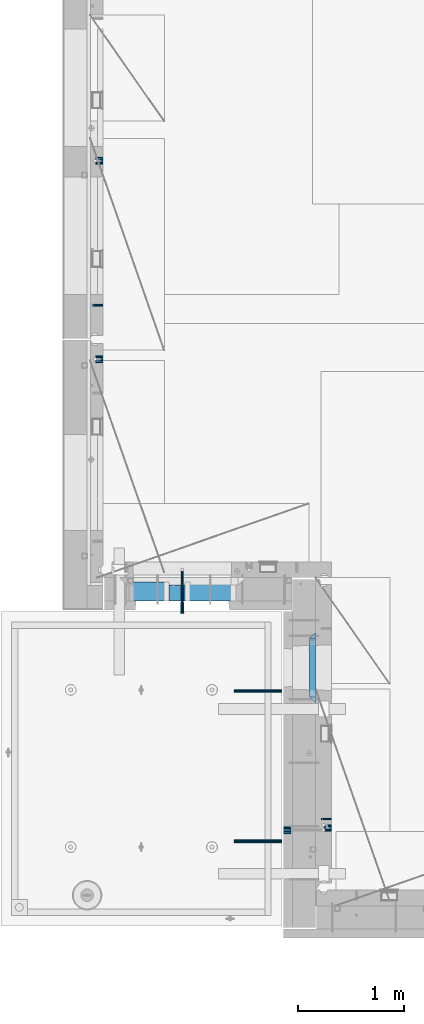
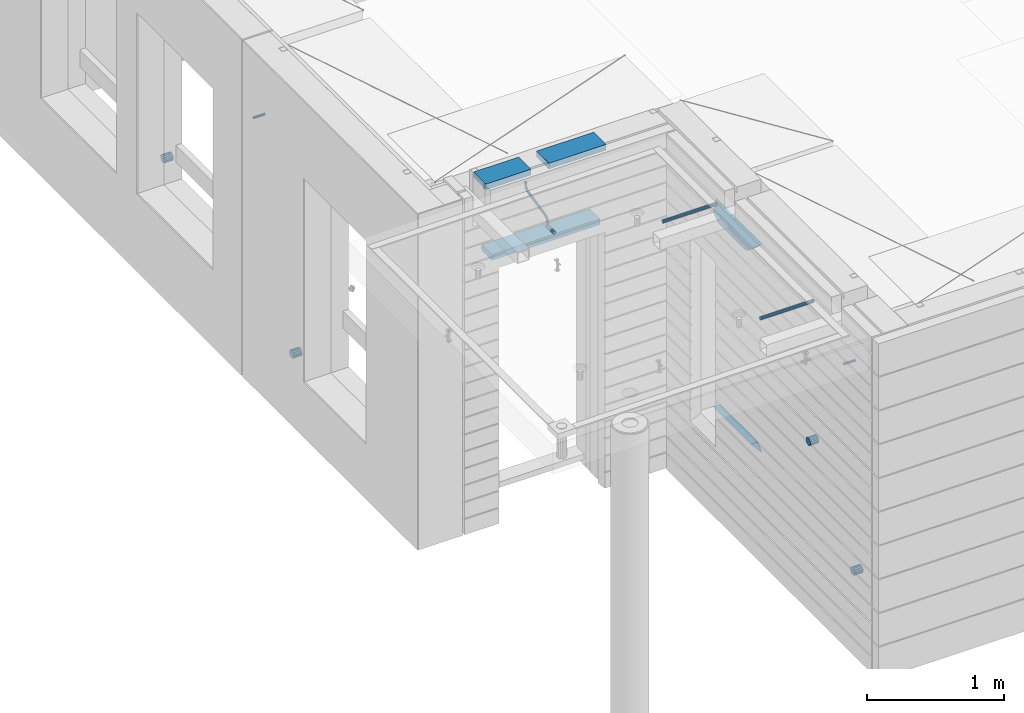
# One storey, part 139 of 350: 16 beams, 9 elements without a shape of their own.
"""IFC2X3 building model written with IfcOpenShell, lengths in millimetres."""

import ifcopenshell
import ifcopenshell.guid

model = None  # the IFC model being written
_history = None  # IfcOwnerHistory: only IFC2X3 demands one
_inside = {}  # id of a spatial element -> (the spatial element, [elements in it])
_under = {}  # id of a project, library or spatial element -> (it, [spatial elements below it])
_declared = {}  # id of a project -> (the project, [libraries it declares])
_typed = {}  # id of a type object -> (the type object, [elements of that type])
_made_of = {}  # id of a material, layer set ... -> (it, [elements and type objects made of it])


def new_model(schema):
    """Start an empty IFC model of exactly this schema.

    Asked for "IFC4X3", IfcOpenShell would pick the latest addendum, in which some entities
    have other attributes; the version numbers below select the first issue.
    IFC2X3 requires an IfcOwnerHistory on every rooted entity: one is made here for all.
    """
    global model, _history
    if schema == "IFC4X3":
        model = ifcopenshell.file(schema_version=(4, 3, 0, 0))
    else:
        model = ifcopenshell.file(schema=schema)
    _inside.clear()
    _under.clear()
    _declared.clear()
    _typed.clear()
    _made_of.clear()
    _history = None
    if model.schema == "IFC2X3":
        org = make("IfcOrganization", Name="unknown")
        user = make(
            "IfcPersonAndOrganization",
            ThePerson=make("IfcPerson", FamilyName="unknown"),
            TheOrganization=org,
        )
        app = make(
            "IfcApplication",
            ApplicationDeveloper=org,
            Version="unknown",
            ApplicationFullName="unknown",
            ApplicationIdentifier="unknown",
        )
        _history = make(
            "IfcOwnerHistory",
            OwningUser=user,
            OwningApplication=app,
            ChangeAction="ADDED",
            CreationDate=0,
        )
    return model


def make(cls, **values):
    """One entity of the class cls with the attributes given. An attribute that is None is left unset."""
    return model.create_entity(
        cls, **{name: value for name, value in values.items() if value is not None}
    )


def rooted(cls, **values):
    """An entity with a GlobalId (a new one), such as an element, a storey or a relation."""
    return make(cls, GlobalId=ifcopenshell.guid.new(), OwnerHistory=_history, **values)


def si_unit(unit_type, name, prefix=None):
    """IfcSIUnit, for example si_unit("LENGTHUNIT", "METRE", prefix="MILLI")."""
    return make("IfcSIUnit", UnitType=unit_type, Prefix=prefix, Name=name)


def assignment(units):
    """IfcUnitAssignment: the units of a project."""
    return None if units is None else make("IfcUnitAssignment", Units=units)


def point(xyz):
    """IfcCartesianPoint."""
    return None if xyz is None else make("IfcCartesianPoint", Coordinates=xyz)


def direction(xyz):
    """IfcDirection."""
    return None if xyz is None else make("IfcDirection", DirectionRatios=xyz)


def frame(location, z_axis=None, x_axis=None):
    """IfcAxis2Placement3D, a coordinate frame: its origin and axes. An axis left out is left unset."""
    return make(
        "IfcAxis2Placement3D",
        Location=point(location),
        Axis=direction(z_axis),
        RefDirection=direction(x_axis),
    )


def origin_with_axes():
    """The frame at (0, 0, 0) with the z axis (0, 0, 1) and the x axis (1, 0, 0) written out."""
    return frame((0.0, 0.0, 0.0), z_axis=(0.0, 0.0, 1.0), x_axis=(1.0, 0.0, 0.0))


def place(relative_to, where):
    """IfcLocalPlacement: puts the frame where relative to a parent placement (None: the world)."""
    return make(
        "IfcLocalPlacement", PlacementRelTo=relative_to, RelativePlacement=where
    )


def context(
    kind, dimensions, precision=None, world=None, true_north=None, identifier=None
):
    """IfcGeometricRepresentationContext, for example the 3D "Model" context."""
    return make(
        "IfcGeometricRepresentationContext",
        ContextIdentifier=identifier,
        ContextType=kind,
        CoordinateSpaceDimension=dimensions,
        Precision=precision,
        WorldCoordinateSystem=world,
        TrueNorth=true_north,
    )


def subcontext(parent, identifier, kind, view, scale=None):
    """IfcGeometricRepresentationSubContext, for example "Body" below "Model"."""
    return make(
        "IfcGeometricRepresentationSubContext",
        ContextIdentifier=identifier,
        ContextType=kind,
        ParentContext=parent,
        TargetScale=scale,
        TargetView=view,
    )


def project(units=None, contexts=None):
    """IfcProject with its units and contexts."""
    return rooted(
        "IfcProject",
        Name="project",
        RepresentationContexts=contexts,
        UnitsInContext=assignment(units),
    )


def spatial(cls, under=None, at=None, **own):
    """A site, building, storey or space (cls), placed at a placement, below another one or the project."""
    s = rooted(cls, ObjectPlacement=at, **own)
    if under is not None:
        _under.setdefault(under.id(), (under, []))[1].append(s)
    return s


def faces_of(points, faces, orient=None, outer=None):
    """IfcFace entities. A face is a list of loops; a loop is a list of indices into points, from 0.

    orient and outer hold one flag for each loop. By default every Orientation is true, the
    first loop of a face is its IfcFaceOuterBound and the others are IfcFaceBound.
    """
    made = []
    for i, loops in enumerate(faces):
        bounds = []
        for j, loop in enumerate(loops):
            is_outer = j == 0 if outer is None else outer[i][j]
            bounds.append(
                make(
                    "IfcFaceOuterBound" if is_outer else "IfcFaceBound",
                    Bound=make("IfcPolyLoop", Polygon=[points[k] for k in loop]),
                    Orientation=True if orient is None else orient[i][j],
                )
            )
        made.append(make("IfcFace", Bounds=bounds))
    return made


def faceted_brep(points, faces, orient=None, outer=None, voids=None):
    """IfcFacetedBrep: a solid bounded by flat faces; with voids (closed shells), ...WithVoids."""
    shared = [point(p) for p in points]
    hull = make("IfcClosedShell", CfsFaces=faces_of(shared, faces, orient, outer))
    if voids is None:
        return make("IfcFacetedBrep", Outer=hull)
    return make(
        "IfcFacetedBrepWithVoids",
        Outer=hull,
        Voids=[
            make(cls, CfsFaces=faces_of(shared, fs, o, b)) for cls, fs, o, b in voids
        ],
    )


def shape(context_of_items, identifier, shape_type, items):
    """IfcShapeRepresentation: the items that make up one representation, for example the "Body"."""
    return make(
        "IfcShapeRepresentation",
        ContextOfItems=context_of_items,
        RepresentationIdentifier=identifier,
        RepresentationType=shape_type,
        Items=items,
    )


def material(Name=None, Category=None):
    """IfcMaterial."""
    return make("IfcMaterial", Name=Name, Category=Category)


def made_of(thing, what):
    """Note that an element or type object is made of a material, layer set ...; save() writes the relation."""
    if what is not None:
        _made_of.setdefault(what.id(), (what, []))[1].append(thing)
    return thing


def type_object(cls, material=None, **own):
    """A type object (cls), such as IfcWallType, which elements share."""
    return made_of(rooted(cls, **own), material)


def element(
    cls,
    number,
    at=None,
    inside=None,
    cuts=None,
    type_object=None,
    material=None,
    context=None,
    identifier="Body",
    shape_type=None,
    held_by="IfcProductDefinitionShape",
    body=None,
    shapes=None,
    **own,
):
    """One element of the class cls, such as IfcWall. Its Tag is "e" and its number.

    at: its placement. inside: the storey or other place that contains it. cuts: it is an
    opening in that element (IfcRelVoidsElement). A single representation is given by context,
    identifier, shape_type and body (its items); several are given by shapes. held_by: the class
    of the entity that holds the representations. save() writes the other relations.
    """
    e = rooted(cls, Tag="e%d" % number, ObjectPlacement=at, **own)
    if body is not None:
        shapes = [shape(context, identifier, shape_type, body)]
    if shapes is not None:
        e.Representation = make(held_by, Representations=shapes)
    if inside is not None:
        _inside.setdefault(inside.id(), (inside, []))[1].append(e)
    if cuts is not None:
        rooted(
            "IfcRelVoidsElement", RelatingBuildingElement=cuts, RelatedOpeningElement=e
        )
    if type_object is not None:
        _typed.setdefault(type_object.id(), (type_object, []))[1].append(e)
    return made_of(e, material)


def aggregate(whole, parts):
    """IfcRelAggregates: a whole, such as a stair, and the parts it consists of."""
    return rooted("IfcRelAggregates", RelatingObject=whole, RelatedObjects=parts)


def save(model, path):
    """Write the relations noted so far, then the file.

    IfcRelAggregates (storeys below a building ...), IfcRelContainedInSpatialStructure (elements
    in a storey), IfcRelDefinesByType, IfcRelAssociatesMaterial and IfcRelDeclares: one each for
    every whole, place, type object, material and project.
    """
    for whole, parts in _under.values():
        aggregate(whole, parts)
    for where, things in _inside.values():
        rooted(
            "IfcRelContainedInSpatialStructure",
            RelatedElements=things,
            RelatingStructure=where,
        )
    for kind, things in _typed.values():
        rooted("IfcRelDefinesByType", RelatedObjects=things, RelatingType=kind)
    for what, things in _made_of.values():
        rooted("IfcRelAssociatesMaterial", RelatedObjects=things, RelatingMaterial=what)
    for by, libraries in _declared.values():
        rooted("IfcRelDeclares", RelatingContext=by, RelatedDefinitions=libraries)
    model.write(path)


model = new_model("IFC2X3")

# Units and contexts
model_context = context("Model", 3, precision=1e-05, world=origin_with_axes())
body_context = subcontext(model_context, "Body", "Model", "MODEL_VIEW")
ifc_project = project(units=[si_unit("LENGTHUNIT", "METRE", prefix="MILLI"), si_unit("AREAUNIT", "SQUARE_METRE"), si_unit("VOLUMEUNIT", "CUBIC_METRE"), si_unit("MASSUNIT", "GRAM", prefix="KILO"), si_unit("TIMEUNIT", "SECOND"), si_unit("PLANEANGLEUNIT", "RADIAN"), si_unit("SOLIDANGLEUNIT", "STERADIAN"), si_unit("THERMODYNAMICTEMPERATUREUNIT", "DEGREE_CELSIUS"), si_unit("LUMINOUSINTENSITYUNIT", "LUMEN")], contexts=[model_context])

# Site, building, storey
site_placement = place(None, origin_with_axes())
site = spatial("IfcSite", under=ifc_project, at=site_placement, CompositionType="ELEMENT")
building_placement = place(site_placement, origin_with_axes())
building = spatial("IfcBuilding", under=site, at=building_placement, CompositionType="ELEMENT")
storey_placement = place(building_placement, origin_with_axes())
storey = spatial("IfcBuildingStorey", under=building, at=storey_placement, Name="2", CompositionType="ELEMENT", Elevation=0.0)

# Assembly, beam
assembly_1_placement = place(storey_placement, origin_with_axes())
assembly_1 = element("IfcElementAssembly", 1, at=assembly_1_placement, inside=storey, AssemblyPlace="NOTDEFINED", PredefinedType="REINFORCEMENT_UNIT")
ifc_material_1 = material(Name="TIMBER")
beam_type_1 = type_object("IfcBeamType", Name="50X150", PredefinedType="NOTDEFINED")
beam_1_placement = place(assembly_1_placement, frame((8295.00084638596, 10804.9999977209, 87070.0), z_axis=(0.0, 0.0, -1.0), x_axis=(1.0, 0.0, 0.0)))
beam_1 = element("IfcBeam", 2, at=beam_1_placement, type_object=beam_type_1, material=ifc_material_1, ObjectType="50X150", context=body_context, shape_type="Brep", body=[
    faceted_brep([(0.0, 75.0, -25.0), (1.81898940354586e-12, 75.0, 25.0), (909.997711181644, 75.0, 25.0), (909.997711181641, 75.0, -25.0), (1.81898940354586e-12, -75.0000000000009, 25.0), (909.997711181644, -75.0, 25.0), (0.0, -75.0, -25.0), (909.997711181641, -75.0, -25.0)], [[[0, 1, 2, 3]], [[1, 4, 5, 2]], [[4, 6, 7, 5]], [[6, 0, 3, 7]], [[5, 7, 3, 2]], [[6, 4, 1, 0]]]),
])

# Assemblies, beam
assembly_2_placement = place(storey_placement, origin_with_axes())
assembly_2 = element("IfcElementAssembly", 3, at=assembly_2_placement, inside=storey, AssemblyPlace="NOTDEFINED", PredefinedType="REINFORCEMENT_UNIT")
assembly_3_placement = place(assembly_2_placement, origin_with_axes())
assembly_3 = element("IfcElementAssembly", 4, at=assembly_3_placement, Name="Steel Assembly", AssemblyPlace="NOTDEFINED", PredefinedType="RIGID_FRAME")
ifc_material_2 = material(Name="STEEL/Steel_Undefined")
beam_type_2 = type_object("IfcBeamType", PredefinedType="NOTDEFINED")
beam_2_placement = place(assembly_3_placement, frame((10160.0000000031, 8669.99635449804, 86755.0), z_axis=(0.0, -1.0, 0.0), x_axis=(-1.0, 3.00000001838171e-08, 0.0)))
beam_2 = element("IfcBeam", 5, at=beam_2_placement, type_object=beam_type_2, material=ifc_material_2, Name="M16", context=body_context, shape_type="Brep", body=[
    faceted_brep([(0.0, -8.49999999999272, -1.45519152283669e-11), (0.0, -7.36121593215648, 4.24999999998545), (100.000000000262, -7.36121593215648, 4.24999999998545), (100.000000000262, -8.49999999999272, -1.45519152283669e-11), (0.0, -4.24999999998545, 7.36121593216376), (100.000000000262, -4.24999999998545, 7.36121593216376), (0.0, 1.45519152283669e-11, 8.49999999998545), (100.000000000262, 1.45519152283669e-11, 8.49999999998545), (0.0, 4.25000000001455, 7.36121593216376), (100.000000000262, 4.25000000001455, 7.36121593216376), (0.0, 7.36121593217104, 4.24999999998545), (100.000000000262, 7.36121593217104, 4.24999999998545), (0.0, 8.50000000000728, 0.0), (100.000000000262, 8.50000000000728, 0.0), (0.0, 7.36121593217104, -4.25000000001455), (100.000000000262, 7.36121593217104, -4.25000000001455), (0.0, 4.25000000000728, -7.36121593219286), (100.000000000262, 4.25000000000728, -7.36121593219286), (0.0, 7.27595761418343e-12, -8.5), (100.000000000262, 7.27595761418343e-12, -8.5), (0.0, -4.24999999999272, -7.36121593217831), (100.000000000262, -4.24999999999272, -7.36121593217831), (0.0, -7.36121593215648, -4.25), (100.000000000262, -7.36121593215648, -4.25), (0.0, -10.4999999999927, -1.45519152283669e-11), (0.0, -9.09326673972828, -5.25000000001455), (100.000000000262, -9.09326673972828, -5.25000000001455), (100.000000000262, -10.4999999999927, -1.45519152283669e-11), (0.0, -5.24999999998545, -9.09326673974283), (100.000000000262, -5.24999999998545, -9.09326673974283), (0.0, 7.27595761418343e-12, -10.5), (100.000000000262, 7.27595761418343e-12, -10.5), (0.0, 5.25000000001455, -9.09326673975738), (100.000000000262, 5.25000000001455, -9.09326673975738), (0.0, 9.09326673975011, -5.25000000001455), (100.000000000262, 9.09326673975011, -5.25000000001455), (0.0, 10.5000000000073, -1.45519152283669e-11), (100.000000000262, 10.5000000000073, -1.45519152283669e-11), (0.0, 9.09326673975011, 5.25), (100.000000000262, 9.09326673975011, 5.25), (0.0, 5.25000000000728, 9.09326673972828), (100.000000000262, 5.25000000000728, 9.09326673972828), (0.0, 1.45519152283669e-11, 10.4999999999854), (100.000000000262, 1.45519152283669e-11, 10.4999999999854), (0.0, -5.24999999999272, 9.09326673972828), (100.000000000262, -5.24999999999272, 9.09326673972828), (0.0, -9.09326673972828, 5.24999999998545), (100.000000000262, -9.09326673972828, 5.24999999998545)], [[[0, 1, 2, 3]], [[1, 4, 5, 2]], [[4, 6, 7, 5]], [[6, 8, 9, 7]], [[8, 10, 11, 9]], [[10, 12, 13, 11]], [[12, 14, 15, 13]], [[14, 16, 17, 15]], [[16, 18, 19, 17]], [[18, 20, 21, 19]], [[20, 22, 23, 21]], [[22, 0, 3, 23]], [[24, 25, 26, 27]], [[25, 28, 29, 26]], [[28, 30, 31, 29]], [[30, 32, 33, 31]], [[32, 34, 35, 33]], [[34, 36, 37, 35]], [[36, 38, 39, 37]], [[38, 40, 41, 39]], [[40, 42, 43, 41]], [[42, 44, 45, 43]], [[44, 46, 47, 45]], [[46, 24, 27, 47]], [[29, 31, 33, 35, 37, 39, 41, 43, 45, 47, 27, 26], [5, 7, 9, 11, 13, 15, 17, 19, 21, 23, 3, 2]], [[46, 44, 42, 40, 38, 36, 34, 32, 30, 28, 25, 24], [22, 20, 18, 16, 14, 12, 10, 8, 6, 4, 1, 0]]]),
])
aggregate(assembly_3, [beam_2])

assembly_4_placement = place(storey_placement, origin_with_axes())
assembly_4 = element("IfcElementAssembly", 6, at=assembly_4_placement, inside=storey, AssemblyPlace="NOTDEFINED", PredefinedType="REINFORCEMENT_UNIT")
assembly_5_placement = place(assembly_4_placement, origin_with_axes())
assembly_5 = element("IfcElementAssembly", 7, at=assembly_5_placement, Name="Steel Assembly", AssemblyPlace="NOTDEFINED", PredefinedType="RIGID_FRAME")
beam_3_placement = place(assembly_5_placement, frame((7999.99973272466, 13524.9954111548, 86755.0), z_axis=(0.0, -1.0, 0.0), x_axis=(-1.0, 3.00000001838171e-08, 0.0)))
beam_3 = element("IfcBeam", 8, at=beam_3_placement, type_object=beam_type_2, material=ifc_material_2, Name="M16", context=body_context, shape_type="Brep", body=[
    faceted_brep([(0.0, -8.49999999999272, -1.45519152283669e-11), (0.0, -7.36121593215648, 4.24999999998545), (100.000000000262, -7.36121593215648, 4.24999999998545), (100.000000000262, -8.49999999999272, -1.45519152283669e-11), (0.0, -4.24999999998545, 7.36121593216376), (100.000000000262, -4.24999999998545, 7.36121593216376), (0.0, 1.45519152283669e-11, 8.49999999998545), (100.000000000262, 1.45519152283669e-11, 8.49999999998545), (0.0, 4.25000000001455, 7.36121593216376), (100.000000000262, 4.25000000001455, 7.36121593216376), (0.0, 7.36121593217104, 4.24999999998545), (100.000000000262, 7.36121593217104, 4.24999999998545), (0.0, 8.50000000000728, 0.0), (100.000000000262, 8.50000000000728, 0.0), (0.0, 7.36121593217104, -4.25000000001455), (100.000000000262, 7.36121593217104, -4.25000000001455), (0.0, 4.25000000000728, -7.36121593219286), (100.000000000262, 4.25000000000728, -7.36121593219286), (0.0, 7.27595761418343e-12, -8.5), (100.000000000262, 7.27595761418343e-12, -8.5), (0.0, -4.24999999999272, -7.36121593217831), (100.000000000262, -4.24999999999272, -7.36121593217831), (0.0, -7.36121593215648, -4.25), (100.000000000262, -7.36121593215648, -4.25), (0.0, -10.4999999999927, -1.45519152283669e-11), (0.0, -9.09326673972828, -5.25000000001455), (100.000000000262, -9.09326673972828, -5.25000000001455), (100.000000000262, -10.4999999999927, -1.45519152283669e-11), (0.0, -5.24999999998545, -9.09326673974283), (100.000000000262, -5.24999999998545, -9.09326673974283), (0.0, 7.27595761418343e-12, -10.5), (100.000000000262, 7.27595761418343e-12, -10.5), (0.0, 5.25000000001455, -9.09326673975738), (100.000000000262, 5.25000000001455, -9.09326673975738), (0.0, 9.09326673975011, -5.25000000001455), (100.000000000262, 9.09326673975011, -5.25000000001455), (0.0, 10.5000000000073, -1.45519152283669e-11), (100.000000000262, 10.5000000000073, -1.45519152283669e-11), (0.0, 9.09326673975011, 5.25), (100.000000000262, 9.09326673975011, 5.25), (0.0, 5.25000000000728, 9.09326673972828), (100.000000000262, 5.25000000000728, 9.09326673972828), (0.0, 1.45519152283669e-11, 10.4999999999854), (100.000000000262, 1.45519152283669e-11, 10.4999999999854), (0.0, -5.24999999999272, 9.09326673972828), (100.000000000262, -5.24999999999272, 9.09326673972828), (0.0, -9.09326673972828, 5.24999999998545), (100.000000000262, -9.09326673972828, 5.24999999998545)], [[[0, 1, 2, 3]], [[1, 4, 5, 2]], [[4, 6, 7, 5]], [[6, 8, 9, 7]], [[8, 10, 11, 9]], [[10, 12, 13, 11]], [[12, 14, 15, 13]], [[14, 16, 17, 15]], [[16, 18, 19, 17]], [[18, 20, 21, 19]], [[20, 22, 23, 21]], [[22, 0, 3, 23]], [[24, 25, 26, 27]], [[25, 28, 29, 26]], [[28, 30, 31, 29]], [[30, 32, 33, 31]], [[32, 34, 35, 33]], [[34, 36, 37, 35]], [[36, 38, 39, 37]], [[38, 40, 41, 39]], [[40, 42, 43, 41]], [[42, 44, 45, 43]], [[44, 46, 47, 45]], [[46, 24, 27, 47]], [[29, 31, 33, 35, 37, 39, 41, 43, 45, 47, 27, 26], [5, 7, 9, 11, 13, 15, 17, 19, 21, 23, 3, 2]], [[46, 44, 42, 40, 38, 36, 34, 32, 30, 28, 25, 24], [22, 20, 18, 16, 14, 12, 10, 8, 6, 4, 1, 0]]]),
])
aggregate(assembly_5, [beam_3])

# Beam
ifc_material_3 = material()
beam_type_3 = type_object("IfcBeamType", Name="D20", PredefinedType="NOTDEFINED")
beam_4_placement = place(assembly_1_placement, frame((8749.01099987619, 11024.9999999788, 87407.5), z_axis=(-0.000415599999849952, -0.999999913638316, 0.0), x_axis=(-0.000120065999970847, 0.0, -0.999999992792078)))
beam_4 = element("IfcBeam", 9, at=beam_4_placement, type_object=beam_type_3, material=ifc_material_3, Name="JM20", ObjectType="D20", context=body_context, shape_type="Brep", body=[
    faceted_brep([(-0.00120059342589229, -9.99999992792982, -1.81898940354586e-12), (-0.000848598996526562, -7.07106776094588, -7.07106781186667), (20.8232838625408, -7.07356789257938, -7.07106678265518), (20.8229318684025, -10.002500059607, 1.02915510069579e-06), (0.0, 0.0, -10.0), (20.8241329547454, -0.00250013169170415, -9.99999897079033), (0.000849296484375373, 7.07106776086221, -7.07106781186667), (20.8249817580218, 7.06856762922689, -7.07106678265518), (0.00120059338223655, 9.99999992792982, 0.0), (20.8253330549196, 9.99749979629632, 1.0292096703779e-06), (0.000848598952870816, 7.07106776094406, 7.07106781186485), (20.8249810604902, 7.06856762931238, 7.07106884107452), (0.0, 0.0, 10.0), (20.8241319682711, -0.00250013157346984, 10.0000010292097), (-0.000849296528031118, -7.07106776086221, 7.07106781186485), (20.8232831650093, -7.07356789249388, 7.07106884107452), (40.7726384379348, -0.00329752151446883, -6.58672044735795), (39.7990928221261, -7.07432640138177, -3.82422098549978), (37.4482429194322, -10.0031646133011, 2.84466611986682), (35.0971847196925, -7.07413845471456, 9.51339724835998), (34.1231362304388, -0.00303172478197666, 12.2755201487289), (35.0966818461602, 7.06799715509078, 9.51302068687073), (37.4475317487959, 9.9968353670065, 2.84413358148049), (39.798589948623, 7.06780920841811, -3.82459754699994), (56.6134582193044, 7.07017615381483, 5.54543822000414), (58.4514841549535, -0.000808958311608876, 3.2647642042939), (52.1785243256745, 9.99890897559089, 11.0529357620781), (47.7446066006523, 7.06977754058425, 16.5610394651339), (45.909033913209, -0.00137268254729861, 18.8431768828377), (47.7470598488144, -7.07235779467737, 16.562502867102), (52.1819937424152, -10.0010906164425, 11.0550053250008), (56.6159114674811, -7.07195918144498, 5.54690162198131), (69.3564592543262, 7.07539916399401, 19.9729559616771), (71.8492429505422, 0.00468241929229407, 18.4335931317055), (63.3422783694841, 10.0034846953076, 23.6924434484845), (57.3297258917155, 7.07370622078452, 27.4132302674134), (54.8408735180419, 0.00228823604993522, 28.9557299626558), (57.3336572142143, -7.06842850865723, 27.4163671326332), (63.3478380990709, -9.99651403996904, 23.6968796458077), (69.3603905768541, -7.06673556544592, 19.9760928269079), (76.5777462286933, 7.08288398612058, 37.8164513940847), (79.4415723249112, 0.0125518247168657, 37.1939186795262), (69.668627354331, 10.0100419194041, 39.324584867969), (62.7614838343434, 7.07933620645599, 40.8348749661036), (59.9024266654887, 0.00753450659613009, 41.4626142320831), (62.7662527616631, -7.0627976548094, 40.8400815174773), (69.675371634672, -9.98995558832394, 39.3319480425926), (76.5825151560421, -7.05924987514118, 37.8216579454656), (129.308523154614, -6.95261720251074, 279.165101653105), (122.401379637289, -9.88332291525512, 280.675391752207), (132.167580323396, 0.11918449733821, 278.53736238712), (129.303754227207, 7.18951665872737, 279.159895101771), (122.394635352946, 10.1166745919945, 280.668028575839), (115.48749183309, 7.18596887904096, 282.178318674083), (112.628434664337, 0.114167179193828, 282.806057940068), (115.492260760511, -6.95616498219715, 282.183525225417), (137.229133330853, 0.124990099046045, 291.044246086658), (134.740500922577, -6.94638672362635, 292.587289291176), (128.728039615235, -9.87606623611646, 296.308301350005), (122.713767699344, -6.94788191340194, 300.027563864771), (120.220764095546, 0.122875581388143, 301.566383296429), (122.709396503866, 7.19425240406599, 300.02334009195), (128.721857811237, 10.1239319165488, 296.302328033165), (134.736129727069, 7.19574759383795, 292.583065518329), (144.322338774131, 7.20140934720075, 303.436489422069), (146.160972676575, 0.130265372217764, 301.156798210583), (139.887153210904, 10.1305263010836, 308.943580001445), (135.453487538296, 7.20177924807103, 314.452090976518), (133.618522976205, 0.130788491054773, 316.735211326552), (135.457156878736, -6.94035548392276, 314.455520115092), (139.892342441963, -9.86947243781106, 308.948429535751), (144.3260081146, -6.94072538479668, 303.43991856068), (156.971701508781, 7.20585774783103, 310.485308401061), (157.94687002321, 0.134410118034793, 307.72445372366), (154.620179671925, 10.1357074636107, 317.153514265787), (152.26979411245, 7.20769303758607, 323.822926758932), (151.297368814296, 0.137005609693006, 326.586694495105), (152.272537328827, -6.93444202010323, 323.825839817728), (154.624059165726, -9.86429173587385, 317.157633953042), (156.974444725187, -6.93627730985281, 310.488221459855), (171.245024905234, 7.20858667482025, 312.927536511204), (171.245873923646, 0.13695276418548, 309.999971503237), (171.244673387351, 10.1388859125454, 319.998037909079), (171.245025284385, 7.21132092570042, 327.06967187077), (171.245874459855, 0.140819578855371, 329.999971129655), (171.246723478296, -6.93081433178304, 327.072406121697), (171.247074992003, -9.86111357003938, 320.00190472537), (171.246723099146, -6.93354858266321, 312.930270762119), (187.500850232711, -6.93159678041229, 312.930269952591), (187.501202129642, -9.85916176723549, 320.001903914186), (187.50000105724, 0.13890456640911, 309.99997069378), (187.499152038683, 7.21053847703843, 312.927535701752), (187.498800520625, 10.1408377147654, 319.998037099565), (187.499152417557, 7.21327272794042, 327.069671061161), (187.500001593056, 0.142771381122657, 329.999970319972), (187.500850611585, -6.92886252950666, 327.072405311999)], [[[0, 1, 2, 3]], [[1, 4, 5, 2]], [[4, 6, 7, 5]], [[6, 8, 9, 7]], [[8, 10, 11, 9]], [[10, 12, 13, 11]], [[12, 14, 15, 13]], [[14, 0, 3, 15]], [[14, 12, 10, 8, 6, 4, 1, 0]], [[2, 5, 16, 17]], [[3, 2, 17, 18]], [[15, 3, 18, 19]], [[13, 15, 19, 20]], [[11, 13, 20, 21]], [[9, 11, 21, 22]], [[7, 9, 22, 23]], [[5, 7, 23, 16]], [[23, 24, 25, 16]], [[22, 26, 24, 23]], [[21, 27, 26, 22]], [[20, 28, 27, 21]], [[19, 29, 28, 20]], [[18, 30, 29, 19]], [[17, 31, 30, 18]], [[16, 25, 31, 17]], [[24, 32, 33, 25]], [[26, 34, 32, 24]], [[27, 35, 34, 26]], [[28, 36, 35, 27]], [[29, 37, 36, 28]], [[30, 38, 37, 29]], [[31, 39, 38, 30]], [[25, 33, 39, 31]], [[32, 40, 41, 33]], [[34, 42, 40, 32]], [[35, 43, 42, 34]], [[36, 44, 43, 35]], [[37, 45, 44, 36]], [[38, 46, 45, 37]], [[39, 47, 46, 38]], [[33, 41, 47, 39]], [[46, 47, 48, 49]], [[47, 41, 50, 48]], [[41, 40, 51, 50]], [[40, 42, 52, 51]], [[42, 43, 53, 52]], [[43, 44, 54, 53]], [[44, 45, 55, 54]], [[45, 46, 49, 55]], [[48, 50, 56, 57]], [[49, 48, 57, 58]], [[55, 49, 58, 59]], [[54, 55, 59, 60]], [[53, 54, 60, 61]], [[52, 53, 61, 62]], [[51, 52, 62, 63]], [[50, 51, 63, 56]], [[63, 64, 65, 56]], [[62, 66, 64, 63]], [[61, 67, 66, 62]], [[60, 68, 67, 61]], [[59, 69, 68, 60]], [[58, 70, 69, 59]], [[57, 71, 70, 58]], [[56, 65, 71, 57]], [[64, 72, 73, 65]], [[66, 74, 72, 64]], [[67, 75, 74, 66]], [[68, 76, 75, 67]], [[69, 77, 76, 68]], [[70, 78, 77, 69]], [[71, 79, 78, 70]], [[65, 73, 79, 71]], [[72, 80, 81, 73]], [[74, 82, 80, 72]], [[75, 83, 82, 74]], [[76, 84, 83, 75]], [[77, 85, 84, 76]], [[78, 86, 85, 77]], [[79, 87, 86, 78]], [[73, 81, 87, 79]], [[86, 87, 88, 89]], [[87, 81, 90, 88]], [[81, 80, 91, 90]], [[80, 82, 92, 91]], [[82, 83, 93, 92]], [[83, 84, 94, 93]], [[84, 85, 95, 94]], [[85, 86, 89, 95]], [[90, 91, 92, 93, 94, 95, 89, 88]]]),
])

beam_type_4 = type_object("IfcBeamType", Name="D70", PredefinedType="NOTDEFINED")
beam_5_placement = place(assembly_4_placement, frame((7999.99984877319, 14888.5021336579, 85555.0), z_axis=(0.0, 0.0, 1.0), x_axis=(-1.0, 3.00000001838171e-08, 0.0)))
beam_5 = element("IfcBeam", 10, at=beam_5_placement, type_object=beam_type_4, material=ifc_material_3, ObjectType="D70", context=body_context, shape_type="Brep", body=[
    faceted_brep([(0.0, -35.0, 0.0), (0.0, -32.3357836378964, -13.3939201327739), (70.0, -32.3357836378964, -13.3939201327739), (70.0, -35.0, 0.0), (0.0, -24.7487373415279, -24.7487373415352), (70.0, -24.7487373415279, -24.7487373415352), (0.0, -13.3939201327776, -32.3357836379), (70.0, -13.3939201327776, -32.3357836379), (0.0, 0.0, -35.0), (70.0, 0.0, -35.0), (0.0, 13.3939201327776, -32.3357836379), (70.0, 13.3939201327776, -32.3357836379), (0.0, 24.7487373415279, -24.7487373415352), (70.0, 24.7487373415279, -24.7487373415352), (0.0, 32.3357836378964, -13.3939201327739), (70.0, 32.3357836378964, -13.3939201327739), (0.0, 35.0, 0.0), (70.0, 35.0, 0.0), (0.0, 32.3357836378964, 13.3939201327739), (70.0, 32.3357836378964, 13.3939201327739), (0.0, 24.7487373415279, 24.7487373415352), (70.0, 24.7487373415279, 24.7487373415352), (0.0, 13.3939201327776, 32.3357836379), (70.0, 13.3939201327776, 32.3357836379), (0.0, 0.0, 35.0), (70.0, 0.0, 35.0), (0.0, -13.3939201327776, 32.3357836379), (70.0, -13.3939201327776, 32.3357836379), (0.0, -24.7487373415279, 24.7487373415352), (70.0, -24.7487373415279, 24.7487373415352), (0.0, -32.3357836378964, 13.3939201327739), (70.0, -32.3357836378964, 13.3939201327739)], [[[0, 1, 2, 3]], [[1, 4, 5, 2]], [[4, 6, 7, 5]], [[6, 8, 9, 7]], [[8, 10, 11, 9]], [[10, 12, 13, 11]], [[12, 14, 15, 13]], [[14, 16, 17, 15]], [[16, 18, 19, 17]], [[18, 20, 21, 19]], [[20, 22, 23, 21]], [[22, 24, 25, 23]], [[24, 26, 27, 25]], [[26, 28, 29, 27]], [[28, 30, 31, 29]], [[30, 0, 3, 31]], [[5, 7, 9, 11, 13, 15, 17, 19, 21, 23, 25, 27, 29, 31, 3, 2]], [[30, 28, 26, 24, 22, 20, 18, 16, 14, 12, 10, 8, 6, 4, 1, 0]]]),
])

aggregate(assembly_4, [beam_5, assembly_5])

# Assembly, beam
assembly_6_placement = place(storey_placement, origin_with_axes())
assembly_6 = element("IfcElementAssembly", 11, at=assembly_6_placement, inside=storey, AssemblyPlace="NOTDEFINED", PredefinedType="REINFORCEMENT_UNIT")
beam_6_placement = place(assembly_6_placement, frame((7999.99972837123, 13015.0021320444, 84955.0), z_axis=(0.0, 0.0, 1.0), x_axis=(-1.0, 3.00000001838171e-08, 0.0)))
beam_6 = element("IfcBeam", 12, at=beam_6_placement, type_object=beam_type_4, material=ifc_material_3, ObjectType="D70", context=body_context, shape_type="Brep", body=[
    faceted_brep([(0.0, -35.0, 0.0), (0.0, -32.3357836378964, -13.3939201327739), (70.0, -32.3357836378964, -13.3939201327739), (70.0, -35.0, 0.0), (0.0, -24.7487373415279, -24.7487373415352), (70.0, -24.7487373415279, -24.7487373415352), (0.0, -13.3939201327776, -32.3357836379), (70.0, -13.3939201327776, -32.3357836379), (0.0, 0.0, -35.0), (70.0, 0.0, -35.0), (0.0, 13.3939201327776, -32.3357836379), (70.0, 13.3939201327776, -32.3357836379), (0.0, 24.7487373415279, -24.7487373415352), (70.0, 24.7487373415279, -24.7487373415352), (0.0, 32.3357836378964, -13.3939201327739), (70.0, 32.3357836378964, -13.3939201327739), (0.0, 35.0, 0.0), (70.0, 35.0, 0.0), (0.0, 32.3357836378964, 13.3939201327739), (70.0, 32.3357836378964, 13.3939201327739), (0.0, 24.7487373415279, 24.7487373415352), (70.0, 24.7487373415279, 24.7487373415352), (0.0, 13.3939201327776, 32.3357836379), (70.0, 13.3939201327776, 32.3357836379), (0.0, 0.0, 35.0), (70.0, 0.0, 35.0), (0.0, -13.3939201327776, 32.3357836379), (70.0, -13.3939201327776, 32.3357836379), (0.0, -24.7487373415279, 24.7487373415352), (70.0, -24.7487373415279, 24.7487373415352), (0.0, -32.3357836378964, 13.3939201327739), (70.0, -32.3357836378964, 13.3939201327739)], [[[0, 1, 2, 3]], [[1, 4, 5, 2]], [[4, 6, 7, 5]], [[6, 8, 9, 7]], [[8, 10, 11, 9]], [[10, 12, 13, 11]], [[12, 14, 15, 13]], [[14, 16, 17, 15]], [[16, 18, 19, 17]], [[18, 20, 21, 19]], [[20, 22, 23, 21]], [[22, 24, 25, 23]], [[24, 26, 27, 25]], [[26, 28, 29, 27]], [[28, 30, 31, 29]], [[30, 0, 3, 31]], [[5, 7, 9, 11, 13, 15, 17, 19, 21, 23, 25, 27, 29, 31, 3, 2]], [[30, 28, 26, 24, 22, 20, 18, 16, 14, 12, 10, 8, 6, 4, 1, 0]]]),
])
aggregate(assembly_6, [beam_6])

# Beam
beam_7_placement = place(assembly_2_placement, frame((10160.0000000031, 8585.00172002957, 84954.9999999969), z_axis=(0.0, 0.0, 1.0), x_axis=(-1.0, 3.00000001838171e-08, 0.0)))
beam_7 = element("IfcBeam", 13, at=beam_7_placement, type_object=beam_type_4, material=ifc_material_3, ObjectType="D70", context=body_context, shape_type="Brep", body=[
    faceted_brep([(0.0, -35.0, 0.0), (0.0, -32.3357836378964, -13.3939201327739), (70.0, -32.3357836378964, -13.3939201327739), (70.0, -35.0, 0.0), (0.0, -24.7487373415279, -24.7487373415352), (70.0, -24.7487373415279, -24.7487373415352), (0.0, -13.3939201327776, -32.3357836379), (70.0, -13.3939201327776, -32.3357836379), (0.0, 0.0, -35.0), (70.0, 0.0, -35.0), (0.0, 13.3939201327776, -32.3357836379), (70.0, 13.3939201327776, -32.3357836379), (0.0, 24.7487373415279, -24.7487373415352), (70.0, 24.7487373415279, -24.7487373415352), (0.0, 32.3357836378964, -13.3939201327739), (70.0, 32.3357836378964, -13.3939201327739), (0.0, 35.0, 0.0), (70.0, 35.0, 0.0), (0.0, 32.3357836378964, 13.3939201327739), (70.0, 32.3357836378964, 13.3939201327739), (0.0, 24.7487373415279, 24.7487373415352), (70.0, 24.7487373415279, 24.7487373415352), (0.0, 13.3939201327776, 32.3357836379), (70.0, 13.3939201327776, 32.3357836379), (0.0, 0.0, 35.0), (70.0, 0.0, 35.0), (0.0, -13.3939201327776, 32.3357836379), (70.0, -13.3939201327776, 32.3357836379), (0.0, -24.7487373415279, 24.7487373415352), (70.0, -24.7487373415279, 24.7487373415352), (0.0, -32.3357836378964, 13.3939201327739), (70.0, -32.3357836378964, 13.3939201327739)], [[[0, 1, 2, 3]], [[1, 4, 5, 2]], [[4, 6, 7, 5]], [[6, 8, 9, 7]], [[8, 10, 11, 9]], [[10, 12, 13, 11]], [[12, 14, 15, 13]], [[14, 16, 17, 15]], [[16, 18, 19, 17]], [[18, 20, 21, 19]], [[20, 22, 23, 21]], [[22, 24, 25, 23]], [[24, 26, 27, 25]], [[26, 28, 29, 27]], [[28, 30, 31, 29]], [[30, 0, 3, 31]], [[5, 7, 9, 11, 13, 15, 17, 19, 21, 23, 25, 27, 29, 31, 3, 2]], [[30, 28, 26, 24, 22, 20, 18, 16, 14, 12, 10, 8, 6, 4, 1, 0]]]),
])

beam_8_placement = place(assembly_2_placement, frame((9705.0, 8564.99633327303, 86255.0), z_axis=(0.0, 0.0, 1.0), x_axis=(1.0, 0.0, 0.0)))
beam_8 = element("IfcBeam", 14, at=beam_8_placement, type_object=beam_type_4, material=ifc_material_3, ObjectType="D70", context=body_context, shape_type="Brep", body=[
    faceted_brep([(0.0, -35.0, 0.0), (0.0, -32.3357836378964, -13.3939201327739), (70.0, -32.3357836378964, -13.3939201327739), (70.0, -35.0, 0.0), (0.0, -24.7487373415279, -24.7487373415352), (70.0, -24.7487373415279, -24.7487373415352), (0.0, -13.3939201327776, -32.3357836379), (70.0, -13.3939201327776, -32.3357836379), (0.0, 0.0, -35.0), (70.0, 0.0, -35.0), (0.0, 13.3939201327776, -32.3357836379), (70.0, 13.3939201327776, -32.3357836379), (0.0, 24.7487373415279, -24.7487373415352), (70.0, 24.7487373415279, -24.7487373415352), (0.0, 32.3357836378964, -13.3939201327739), (70.0, 32.3357836378964, -13.3939201327739), (0.0, 35.0, 0.0), (70.0, 35.0, 0.0), (0.0, 32.3357836378964, 13.3939201327739), (70.0, 32.3357836378964, 13.3939201327739), (0.0, 24.7487373415279, 24.7487373415352), (70.0, 24.7487373415279, 24.7487373415352), (0.0, 13.3939201327776, 32.3357836379), (70.0, 13.3939201327776, 32.3357836379), (0.0, 0.0, 35.0), (70.0, 0.0, 35.0), (0.0, -13.3939201327776, 32.3357836379), (70.0, -13.3939201327776, 32.3357836379), (0.0, -24.7487373415279, 24.7487373415352), (70.0, -24.7487373415279, 24.7487373415352), (0.0, -32.3357836378964, 13.3939201327739), (70.0, -32.3357836378964, 13.3939201327739)], [[[0, 1, 2, 3]], [[1, 4, 5, 2]], [[4, 6, 7, 5]], [[6, 8, 9, 7]], [[8, 10, 11, 9]], [[10, 12, 13, 11]], [[12, 14, 15, 13]], [[14, 16, 17, 15]], [[16, 18, 19, 17]], [[18, 20, 21, 19]], [[20, 22, 23, 21]], [[22, 24, 25, 23]], [[24, 26, 27, 25]], [[26, 28, 29, 27]], [[28, 30, 31, 29]], [[30, 0, 3, 31]], [[5, 7, 9, 11, 13, 15, 17, 19, 21, 23, 25, 27, 29, 31, 3, 2]], [[30, 28, 26, 24, 22, 20, 18, 16, 14, 12, 10, 8, 6, 4, 1, 0]]]),
])

beam_type_5 = type_object("IfcBeamType", Name="D30", PredefinedType="NOTDEFINED")
beam_9_placement = place(assembly_1_placement, frame((8749.00366673359, 10610.0, 87205.0), z_axis=(0.0, 0.0, 1.0), x_axis=(0.0, 1.0, 0.0)))
beam_9 = element("IfcBeam", 15, at=beam_9_placement, type_object=beam_type_5, material=ifc_material_3, Name="AJ 10.20", ObjectType="D30", context=body_context, shape_type="Brep", body=[
    faceted_brep([(0.0, -15.0, 0.0), (0.0, -12.9903810567666, -7.5), (105.0, -12.9903810567666, -7.5), (105.0, -15.0, 0.0), (0.0, -7.5, -12.9903810567666), (105.0, -7.5, -12.990381056763), (0.0, 0.0, -15.0), (105.0, 0.0, -15.0), (0.0, 7.5, -12.9903810567666), (105.0, 7.5, -12.990381056763), (0.0, 12.9903810567666, -7.5), (105.0, 12.9903810567666, -7.5), (0.0, 15.0, 0.0), (105.0, 15.0, 0.0), (0.0, 12.9903810567666, 7.5), (105.0, 12.9903810567666, 7.5), (0.0, 7.5, 12.9903810567666), (105.0, 7.5, 12.990381056763), (0.0, 0.0, 15.0), (105.0, 0.0, 15.0), (0.0, -7.5, 12.9903810567666), (105.0, -7.5, 12.990381056763), (0.0, -12.9903810567666, 7.5), (105.0, -12.9903810567666, 7.5)], [[[0, 1, 2, 3]], [[1, 4, 5, 2]], [[4, 6, 7, 5]], [[6, 8, 9, 7]], [[8, 10, 11, 9]], [[10, 12, 13, 11]], [[12, 14, 15, 13]], [[14, 16, 17, 15]], [[16, 18, 19, 17]], [[18, 20, 21, 19]], [[20, 22, 23, 21]], [[22, 0, 3, 23]], [[5, 7, 9, 11, 13, 15, 17, 19, 21, 23, 3, 2]], [[22, 20, 18, 16, 14, 12, 10, 8, 6, 4, 1, 0]]]),
])

# Assemblies, beams
assembly_7_placement = place(storey_placement, origin_with_axes())
assembly_7 = element("IfcElementAssembly", 16, at=assembly_7_placement, inside=storey, AssemblyPlace="NOTDEFINED", PredefinedType="REINFORCEMENT_UNIT")
assembly_8_placement = place(assembly_7_placement, origin_with_axes())
assembly_8 = element("IfcElementAssembly", 17, at=assembly_8_placement, Name="Steel Assembly", AssemblyPlace="NOTDEFINED", PredefinedType="RIGID_FRAME")
ifc_material_4 = material(Name="STEEL/S235JR")
beam_10_placement = place(assembly_8_placement, frame((9689.97466054669, 8459.99985675633, 87575.0), z_axis=(0.0, 0.0, 1.0), x_axis=(-1.0, 3.00000001838171e-08, 0.0)))
beam_10 = element("IfcBeam", 18, at=beam_10_placement, type_object=beam_type_5, material=ifc_material_4, Name="Rd30", ObjectType="D30", context=body_context, shape_type="Brep", body=[
    faceted_brep([(0.0, -15.0, 0.0), (0.0, -12.9903810567666, -7.5), (450.0, -12.9903810567666, -7.5), (450.0, -15.0, 0.0), (0.0, -7.5, -12.9903810567666), (450.0, -7.5, -12.990381056763), (0.0, 0.0, -15.0), (450.0, 0.0, -15.0), (0.0, 7.5, -12.9903810567666), (450.0, 7.5, -12.990381056763), (0.0, 12.9903810567666, -7.5), (450.0, 12.9903810567666, -7.5), (0.0, 15.0, 0.0), (450.0, 15.0, 0.0), (0.0, 12.9903810567666, 7.5), (450.0, 12.9903810567666, 7.5), (0.0, 7.5, 12.9903810567666), (450.0, 7.5, 12.990381056763), (0.0, 0.0, 15.0), (450.0, 0.0, 15.0), (0.0, -7.5, 12.9903810567666), (450.0, -7.5, 12.990381056763), (0.0, -12.9903810567666, 7.5), (450.0, -12.9903810567666, 7.5)], [[[0, 1, 2, 3]], [[1, 4, 5, 2]], [[4, 6, 7, 5]], [[6, 8, 9, 7]], [[8, 10, 11, 9]], [[10, 12, 13, 11]], [[12, 14, 15, 13]], [[14, 16, 17, 15]], [[16, 18, 19, 17]], [[18, 20, 21, 19]], [[20, 22, 23, 21]], [[22, 0, 3, 23]], [[5, 7, 9, 11, 13, 15, 17, 19, 21, 23, 3, 2]], [[22, 20, 18, 16, 14, 12, 10, 8, 6, 4, 1, 0]]]),
])
aggregate(assembly_8, [beam_10])
assembly_9_placement = place(assembly_7_placement, origin_with_axes())
assembly_9 = element("IfcElementAssembly", 19, at=assembly_9_placement, Name="Steel Assembly", AssemblyPlace="NOTDEFINED", PredefinedType="RIGID_FRAME")
aggregate(assembly_7, [assembly_8, assembly_9])
beam_11_placement = place(assembly_9_placement, frame((9689.98478639016, 9879.99985700661, 87575.0), z_axis=(0.0, 0.0, 1.0), x_axis=(-1.0, 3.00000001838171e-08, 0.0)))
beam_11 = element("IfcBeam", 20, at=beam_11_placement, type_object=beam_type_5, material=ifc_material_4, Name="Rd30", ObjectType="D30", context=body_context, shape_type="Brep", body=[
    faceted_brep([(0.0, -15.0, 0.0), (0.0, -12.9903810567666, -7.5), (450.0, -12.9903810567666, -7.5), (450.0, -15.0, 0.0), (0.0, -7.5, -12.9903810567666), (450.0, -7.5, -12.990381056763), (0.0, 0.0, -15.0), (450.0, 0.0, -15.0), (0.0, 7.5, -12.9903810567666), (450.0, 7.5, -12.990381056763), (0.0, 12.9903810567666, -7.5), (450.0, 12.9903810567666, -7.5), (0.0, 15.0, 0.0), (450.0, 15.0, 0.0), (0.0, 12.9903810567666, 7.5), (450.0, 12.9903810567666, 7.5), (0.0, 7.5, 12.9903810567666), (450.0, 7.5, 12.990381056763), (0.0, 0.0, 15.0), (450.0, 0.0, 15.0), (0.0, -7.5, 12.9903810567666), (450.0, -7.5, 12.990381056763), (0.0, -12.9903810567666, 7.5), (450.0, -12.9903810567666, 7.5)], [[[0, 1, 2, 3]], [[1, 4, 5, 2]], [[4, 6, 7, 5]], [[6, 8, 9, 7]], [[8, 10, 11, 9]], [[10, 12, 13, 11]], [[12, 14, 15, 13]], [[14, 16, 17, 15]], [[16, 18, 19, 17]], [[18, 20, 21, 19]], [[20, 22, 23, 21]], [[22, 0, 3, 23]], [[5, 7, 9, 11, 13, 15, 17, 19, 21, 23, 3, 2]], [[22, 20, 18, 16, 14, 12, 10, 8, 6, 4, 1, 0]]]),
])
aggregate(assembly_9, [beam_11])

# Beam
ifc_material_5 = material(Name="CONCRETE/C25/30")
beam_type_6 = type_object("IfcBeamType", PredefinedType="NOTDEFINED")
beam_12_placement = place(assembly_2_placement, frame((9980.0, 10435.0000000021, 87145.0), z_axis=(0.0, 0.0, -1.0), x_axis=(0.0, -1.0, 0.0)))
beam_12 = element("IfcBeam", 21, at=beam_12_placement, type_object=beam_type_6, material=ifc_material_5, Name="SK", context=body_context, shape_type="Brep", body=[
    faceted_brep([(60.0000000000073, 30.0, 30.0), (0.0, -30.0, -30.0), (60.0000000000073, -30.0, 30.0), (609.999618530263, -30.0, 30.0), (609.999618530263, 30.0, 30.0), (669.999575761092, -30.0, -30.0)], [[[0, 1, 2]], [[0, 2, 3, 4]], [[1, 0, 4, 5]], [[2, 1, 5, 3]], [[5, 4, 3]]]),
])

beam_13_placement = place(assembly_2_placement, frame((9980.00000000155, 10375.0000000021, 87085.0), z_axis=(0.0, 0.0, -1.0), x_axis=(0.0, -1.0, 0.0)))
beam_13 = element("IfcBeam", 22, at=beam_13_placement, type_object=beam_type_6, material=ifc_material_5, Name="SK", context=body_context, shape_type="Brep", body=[
    faceted_brep([(65.6752514367672, 29.999999998452, 26.2930726477352), (0.0, 30.0, -30.0), (0.0, -30.0, -30.0), (64.0536298152292, -29.999999998452, 24.9031112581433), (64.0536298152292, -29.999999998452, 24.0540540541406), (65.6752514367672, 29.999999998452, 25.6756756756804), (485.94556447622, -30.0, 24.0540540540533), (484.323942854597, 30.0, 25.6756756756804), (485.94556447622, -30.0, 24.9034748914273), (484.323942854597, 30.0, 26.293436281092), (549.999575761092, 29.999999998452, -30.0), (549.999575761092, -29.999999998452, -30.0)], [[[0, 1, 2, 3]], [[4, 5, 0, 3]], [[6, 7, 5, 4]], [[7, 6, 8, 9]], [[1, 0, 5, 7, 9, 10]], [[2, 1, 10, 11]], [[6, 4, 3, 2, 11, 8]], [[8, 11, 10, 9]]]),
])

beam_14_placement = place(assembly_2_placement, frame((9980.0, 9765.00042424099, 85350.0), z_axis=(0.0, 0.0, 1.0), x_axis=(0.0, 1.0, 0.0)))
beam_14 = element("IfcBeam", 23, at=beam_14_placement, type_object=beam_type_6, material=ifc_material_5, Name="SK", context=body_context, shape_type="Brep", body=[
    faceted_brep([(669.999575761092, -30.0, -30.0), (609.999618530263, 30.0, 30.0), (609.999618530263, -30.0, 30.0), (60.0000000000073, -30.0, 30.0), (0.0, -30.0, -30.0), (60.0000000000073, 30.0, 30.0)], [[[0, 1, 2]], [[3, 4, 0, 2]], [[4, 5, 1, 0]], [[5, 3, 2, 1]], [[5, 4, 3]]]),
])

aggregate(assembly_2, [assembly_3, beam_7, beam_8, beam_12, beam_13, beam_14])

beam_type_7 = type_object("IfcBeamType", PredefinedType="NOTDEFINED")
beam_15_placement = place(assembly_1_placement, frame((8625.00003814753, 10820.0, 87715.0), z_axis=(0.0, 0.0, 1.0), x_axis=(-1.0, 3.00000001838171e-08, 0.0)))
beam_15 = element("IfcBeam", 24, at=beam_15_placement, type_object=beam_type_7, material=ifc_material_1, context=body_context, shape_type="Brep", body=[
    faceted_brep([(0.0, 90.0, -25.0), (0.0, 90.0, 25.0), (379.99983857082, 90.0, 25.0), (379.99983857082, 90.0, -25.0), (0.0, -90.0, 25.0), (379.99983857082, -90.0, 25.0), (0.0, -90.0, -25.0), (379.99983857082, -90.0, -25.0)], [[[0, 1, 2, 3]], [[1, 4, 5, 2]], [[4, 6, 7, 5]], [[6, 0, 3, 7]], [[5, 7, 3, 2]], [[6, 4, 1, 0]]]),
])

beam_16_placement = place(assembly_1_placement, frame((9255.00003814753, 10820.0, 87715.0), z_axis=(0.0, 0.0, 1.0), x_axis=(-1.0, 3.00000001838171e-08, 0.0)))
beam_16 = element("IfcBeam", 25, at=beam_16_placement, type_object=beam_type_7, material=ifc_material_1, context=body_context, shape_type="Brep", body=[
    faceted_brep([(0.0, 90.0, -25.0), (0.0, 90.0, 25.0), (480.99983857082, 90.0, 25.0), (480.99983857082, 90.0, -25.0), (0.0, -90.0, 25.0), (480.99983857082, -90.0, 25.0), (0.0, -90.0, -25.0), (480.99983857082, -90.0, -25.0)], [[[0, 1, 2, 3]], [[1, 4, 5, 2]], [[4, 6, 7, 5]], [[6, 0, 3, 7]], [[5, 7, 3, 2]], [[6, 4, 1, 0]]]),
])

aggregate(assembly_1, [beam_15, beam_9, beam_4, beam_16, beam_1])

save(model, "model.ifc")
